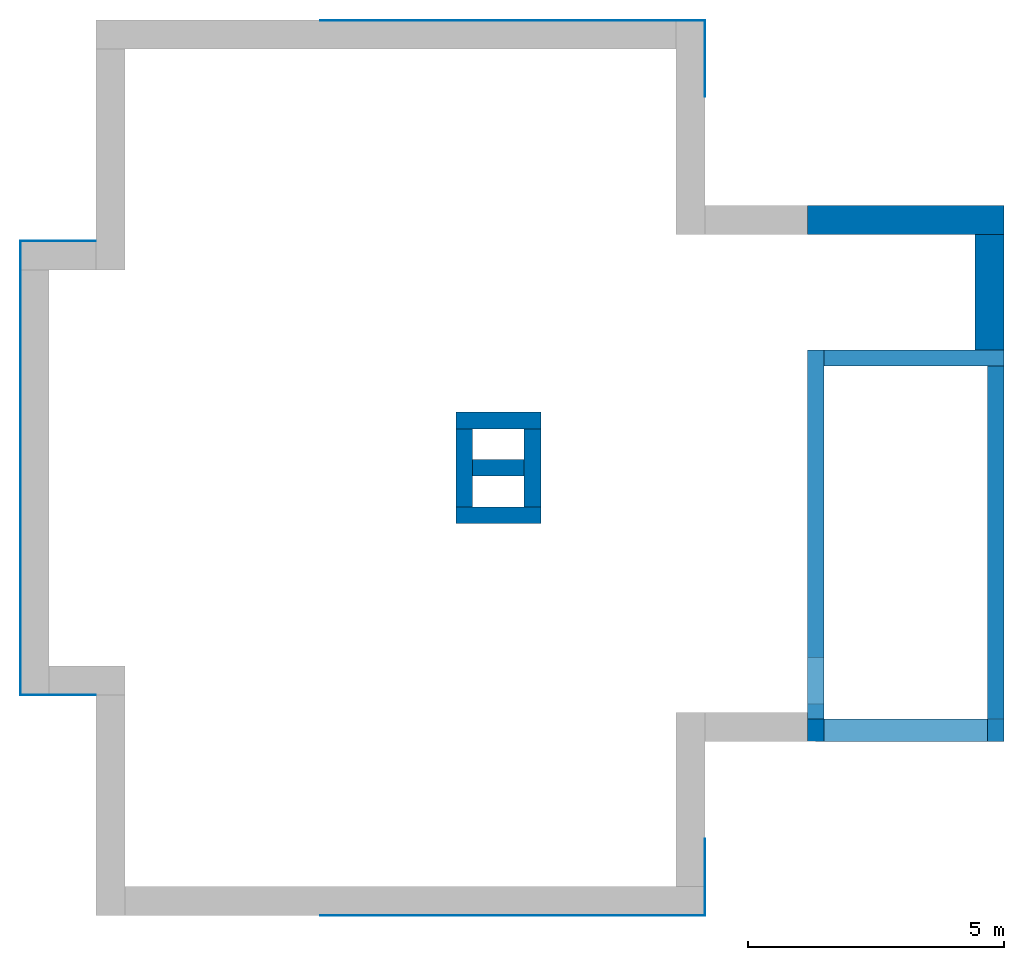
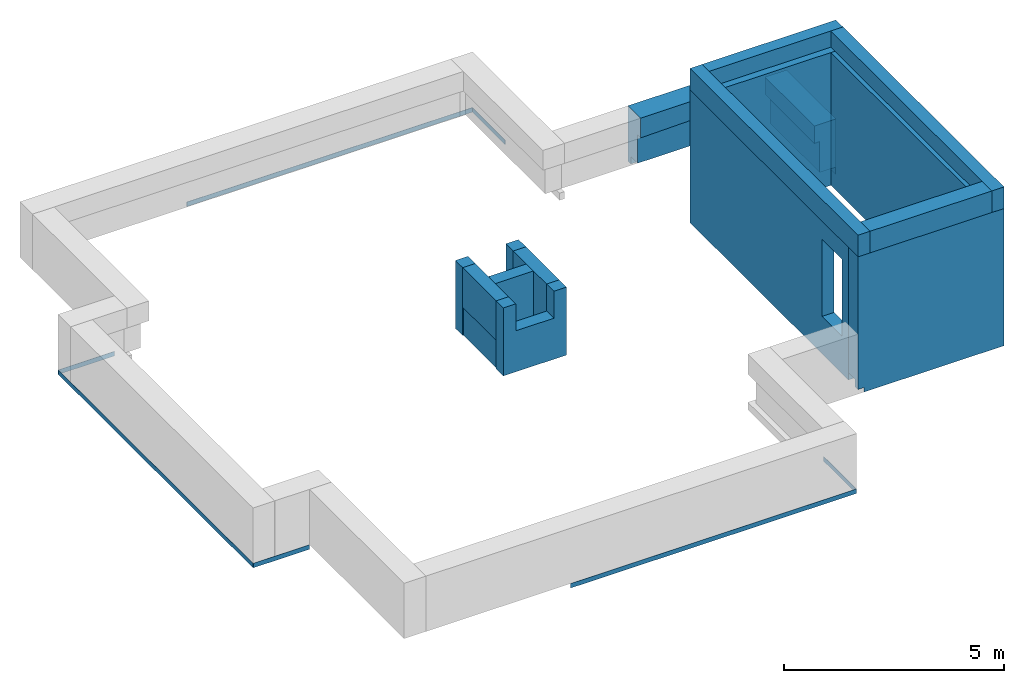
# One storey, part 1 of 2: 22 walls, 6 openings.
"""IFC2X3 building model written with IfcOpenShell, lengths in millimetres."""

from ifc_helpers import new_model, entity, si_unit, converted_unit, derived_unit, direction, frame, frame_2d, origin, origin_2d_with_axis, place, context, subcontext, project, spatial, polyline, rectangle, extrude, clip, bounded_halfspace, faceted_brep, material, material_list, layer, layer_set, layer_usage, type_object, element, save


model = new_model("IFC2X3")

# Units and contexts
model_context = context("Model", 3, precision=0.01, world=origin(), true_north=direction((6.12303176911189e-17, 1.0)))
body_context = subcontext(model_context, "Body", "Model", "MODEL_VIEW")
ifc_project = project(units=[si_unit("LENGTHUNIT", "METRE", prefix="MILLI"), si_unit("AREAUNIT", "SQUARE_METRE"), si_unit("VOLUMEUNIT", "CUBIC_METRE"), converted_unit("PLANEANGLEUNIT", "DEGREE", entity("IfcRatioMeasure", 0.0174532925199433), si_unit("PLANEANGLEUNIT", "RADIAN"), dimensions=[0, 0, 0, 0, 0, 0, 0]), si_unit("MASSUNIT", "GRAM", prefix="KILO"), derived_unit("MASSDENSITYUNIT", [(si_unit("MASSUNIT", "GRAM", prefix="KILO"), 1), (si_unit("LENGTHUNIT", "METRE"), -3)]), si_unit("TIMEUNIT", "SECOND"), si_unit("FREQUENCYUNIT", "HERTZ"), si_unit("THERMODYNAMICTEMPERATUREUNIT", "DEGREE_CELSIUS"), derived_unit("THERMALTRANSMITTANCEUNIT", [(si_unit("MASSUNIT", "GRAM", prefix="KILO"), 1), (si_unit("THERMODYNAMICTEMPERATUREUNIT", "KELVIN"), -1), (si_unit("TIMEUNIT", "SECOND"), -3)]), derived_unit("VOLUMETRICFLOWRATEUNIT", [(si_unit("LENGTHUNIT", "METRE"), 3), (si_unit("TIMEUNIT", "SECOND"), -1)]), si_unit("ELECTRICCURRENTUNIT", "AMPERE"), si_unit("ELECTRICVOLTAGEUNIT", "VOLT"), si_unit("POWERUNIT", "WATT"), si_unit("FORCEUNIT", "NEWTON", prefix="KILO"), si_unit("ILLUMINANCEUNIT", "LUX"), si_unit("LUMINOUSFLUXUNIT", "LUMEN"), si_unit("LUMINOUSINTENSITYUNIT", "CANDELA"), derived_unit("USERDEFINED", [(si_unit("MASSUNIT", "GRAM", prefix="KILO"), -1), (si_unit("LENGTHUNIT", "METRE"), -2), (si_unit("TIMEUNIT", "SECOND"), 3), (si_unit("LUMINOUSFLUXUNIT", "LUMEN"), 1)]), derived_unit("LINEARVELOCITYUNIT", [(si_unit("LENGTHUNIT", "METRE"), 1), (si_unit("TIMEUNIT", "SECOND"), -1)]), si_unit("PRESSUREUNIT", "PASCAL"), derived_unit("USERDEFINED", [(si_unit("LENGTHUNIT", "METRE"), -2), (si_unit("MASSUNIT", "GRAM", prefix="KILO"), 1), (si_unit("TIMEUNIT", "SECOND"), -2)])], contexts=[model_context])

# Site, building, storey
site_placement = place(None, origin())
site = spatial("IfcSite", under=ifc_project, at=site_placement, CompositionType="ELEMENT")
building_placement = place(site_placement, origin())
building = spatial("IfcBuilding", under=site, at=building_placement, CompositionType="ELEMENT")
storey_placement = place(building_placement, frame((0.0, 0.0, 16000.0)))
storey = spatial("IfcBuildingStorey", under=building, at=storey_placement, Name="04 Roof", CompositionType="ELEMENT", Elevation=16000.0)

# Wall
ifc_material_1 = material(Name="03")
ifc_layer_1 = layer(ifc_material_1, 10.0)
ifc_material_2 = material()
ifc_layer_2 = layer(ifc_material_2, 120.0)
ifc_material_3 = material()
ifc_layer_3 = layer(ifc_material_3, 300.0)
ifc_layer_4 = layer(ifc_material_1, 10.0)
ifc_layer_set_1 = layer_set([ifc_layer_1, ifc_layer_2, ifc_layer_3, ifc_layer_4], Name="Basic Wall:00_fal+12 cm")
wall_type_1 = type_object("IfcWallType", Name="Basic Wall:00_fal+12 cm", PredefinedType="STANDARD", material=ifc_layer_set_1)
wall_1_placement = place(storey_placement, frame((30943.4900708518, -73960.8241905963, -465.0)))
element("IfcWall", 1, at=wall_1_placement, inside=storey, type_object=wall_type_1, Name="Basic Wall:00_fal+12 cm", ObjectType="Basic Wall:00_fal+12 cm", context=body_context, shape_type="Brep", body=[
    faceted_brep([(160.0, -220.0, 0.0), (3840.0, -220.0, 0.0), (3840.0, -220.0, 3815.0), (3520.0, -220.0, 3815.0), (320.0, -220.0, 3815.0), (0.0, -220.0, 3815.0), (0.0, -220.0, 1665.0), (0.0, -220.0, 125.0), (160.0, -220.0, 125.0), (0.0, 220.0, 3815.0), (320.0, 220.0, 3815.0), (3520.0, 220.0, 3815.0), (3840.0, 220.0, 3815.0), (3840.0, 220.0, 125.0), (3830.0, 220.0, 125.0), (3830.0, 220.0, 325.0), (3520.0, 220.0, 325.0), (320.0, 220.0, 325.0), (0.0, 220.0, 325.0), (160.0, -210.0, 0.0), (3840.0, -210.0, 0.0), (3840.0, -210.0, 125.0), (160.0, -210.0, 125.0), (0.0, -210.0, 125.0), (0.0, -90.0, 125.0), (3830.0, -90.0, 125.0), (0.0, 210.0, 325.0), (0.0, -90.0, 325.0), (3830.0, -90.0, 325.0)], [[[0, 1, 2, 3, 4, 5, 6, 7, 8]], [[9, 10, 11, 12, 13, 14, 15, 16, 17, 18]], [[1, 0, 19, 20]], [[5, 4, 3, 2, 12, 11, 10, 9]], [[2, 1, 20, 21, 13, 12]], [[0, 8, 22, 19]], [[8, 7, 23, 24, 25, 14, 13, 21, 22]], [[5, 9, 18, 26, 27, 24, 23, 7, 6]], [[15, 28, 27, 26, 18, 17, 16]], [[25, 28, 15, 14]], [[28, 25, 24, 27]], [[22, 21, 20, 19]]]),
])

# Wall, openings
ifc_layer_5 = layer(ifc_material_1, 10.0)
ifc_layer_6 = layer(ifc_material_3, 300.0)
ifc_layer_7 = layer(ifc_material_1, 10.0)
ifc_layer_set_2 = layer_set([ifc_layer_5, ifc_layer_6, ifc_layer_7], Name="Basic Wall:00_fal 300 mm")
ifc_layer_usage_1 = layer_usage(ifc_layer_set_2, "AXIS2", "NEGATIVE", 160.0)
wall_type_2 = type_object("IfcWallType", Name="Basic Wall:00_fal 300 mm", PredefinedType="STANDARD", material=ifc_layer_set_2)
wall_2_placement = place(storey_placement, frame((31103.4900708518, -66525.8241905964, -340.0), z_axis=(0.0, 0.0, 1.0), x_axis=(0.0, -1.0, 0.0)))
wall_2 = element("IfcWallStandardCase", 2, at=wall_2_placement, inside=storey, type_object=wall_type_2, material=ifc_layer_usage_1, Name="Basic Wall:00_fal 300 mm", ObjectType="Basic Wall:00_fal 300 mm", context=body_context, shape_type="SweptSolid", body=[
    extrude(rectangle(XDim=7214.99999999998, YDim=319.999999999997, at=frame_2d((3607.49999999999, 5.11590769747272e-13), x_axis=(-1.0, 0.0))), origin(), (0.0, 0.0, 1.0), 3690.0),
])
opening_1_placement = place(storey_placement, frame((31103.4900708518, -66525.8241905964, -340.0), z_axis=(0.0, 0.0, 1.0), x_axis=(0.0, -1.0, 0.0)))
element("IfcOpeningElement", 3, at=opening_1_placement, cuts=wall_2, Name="Basic Wall:00_fal 300 mm+1", ObjectType="Opening", context=body_context, shape_type="SweptSolid", body=[
    extrude(rectangle(XDim=200.0, YDim=9.9999999999804, at=frame_2d((0.0, -1.08713038571295e-12), x_axis=(0.0, 1.0))), frame((5035.0, 155.0, 100.0), z_axis=(-1.0, 0.0, 0.0), x_axis=(0.0, 1.0, 0.0)), (0.0, 0.0, 1.0), 4724.99999999996),
])
opening_2_placement = place(wall_2_placement, frame((6915.0, -1684.0, 1040.0), z_axis=(0.0, 0.0, 1.0), x_axis=(0.0, 1.0, 0.0)))
element("IfcOpeningElement", 4, at=opening_2_placement, cuts=wall_2, Name="Basic Wall:00_fal 300 mm", ObjectType="Opening", context=body_context, shape_type="SweptSolid", body=[
    extrude(rectangle(XDim=2142.0, YDim=900.000000000003, at=origin_2d_with_axis()), frame((0.0, 450.0, 1071.0), z_axis=(1.0, 0.0, 0.0), x_axis=(0.0, 0.0, 1.0)), (0.0, 0.0, 1.0), 3048.0),
])

# Wall, opening
ifc_layer_usage_2 = layer_usage(ifc_layer_set_2, "AXIS2", "NEGATIVE", 160.0)
wall_3_placement = place(storey_placement, frame((31263.4900708518, -66685.8241905964, -340.0)))
wall_3 = element("IfcWallStandardCase", 5, at=wall_3_placement, inside=storey, type_object=wall_type_2, material=ifc_layer_usage_2, Name="Basic Wall:00_fal 300 mm", ObjectType="Basic Wall:00_fal 300 mm", context=body_context, shape_type="SweptSolid", body=[
    extrude(rectangle(XDim=3519.99999999998, YDim=319.999999999997, at=frame_2d((1759.99999999999, 1.98951966012828e-12), x_axis=(-1.0, 0.0))), origin(), (0.0, 0.0, 1.0), 3690.0),
])
opening_3_placement = place(storey_placement, frame((31263.4900708518, -66685.8241905964, -340.0)))
element("IfcOpeningElement", 6, at=opening_3_placement, cuts=wall_3, Name="Basic Wall:00_fal 300 mm+1", ObjectType="Opening", context=body_context, shape_type="SweptSolid", body=[
    extrude(rectangle(XDim=200.0, YDim=9.99999999999773, at=frame_2d((-1.08713038571295e-12, 0.0), x_axis=(1.0, 0.0))), frame((3210.0, -155.0, 100.0), z_axis=(1.0, 0.0, 0.0), x_axis=(0.0, 0.0, 1.0)), (0.0, 0.0, 1.0), 300.000000000027),
])

ifc_layer_usage_3 = layer_usage(ifc_layer_set_2, "AXIS2", "NEGATIVE", 160.0)
wall_4_placement = place(storey_placement, frame((34623.4900708518, -66845.8241905964, -340.0), z_axis=(0.0, 0.0, 1.0), x_axis=(0.0, -1.0, 0.0)))
wall_4 = element("IfcWallStandardCase", 7, at=wall_4_placement, inside=storey, type_object=wall_type_2, material=ifc_layer_usage_3, Name="Basic Wall:00_fal 300 mm", ObjectType="Basic Wall:00_fal 300 mm", context=body_context, shape_type="SweptSolid", body=[
    extrude(rectangle(XDim=6895.00000000004, YDim=319.999999999997, at=frame_2d((3447.50000000002, 0.0), x_axis=(-1.0, 0.0))), origin(), (0.0, 0.0, 1.0), 3690.0),
])
opening_4_placement = place(storey_placement, frame((34623.4900708518, -66845.8241905964, -340.0), z_axis=(0.0, 0.0, 1.0), x_axis=(0.0, -1.0, 0.0)))
element("IfcOpeningElement", 8, at=opening_4_placement, cuts=wall_4, Name="Basic Wall:00_fal 300 mm+1", ObjectType="Opening", context=body_context, shape_type="SweptSolid", body=[
    extrude(rectangle(XDim=200.0, YDim=4434.99999999997, at=frame_2d((-1.08713038571295e-12, 4.32009983342141e-12), x_axis=(1.0, 0.0))), frame((2217.49999999999, -150.0, 100.0), z_axis=(0.0, 1.0, 0.0), x_axis=(0.0, 0.0, -1.0)), (0.0, 0.0, 1.0), 300.000000000027),
])

# Walls
ifc_layer_usage_4 = layer_usage(ifc_layer_set_2, "AXIS2", "NEGATIVE", 160.0)
wall_5_placement = place(storey_placement, frame((24403.4900708518, -68831.2395851399, -140.0)))
element("IfcWallStandardCase", 9, at=wall_5_placement, inside=storey, type_object=wall_type_2, material=ifc_layer_usage_4, Name="Basic Wall:00_fal 300 mm", ObjectType="Basic Wall:00_fal 300 mm", context=body_context, shape_type="SweptSolid", body=[
    extrude(rectangle(XDim=1000.00000000001, YDim=319.999999999997, at=frame_2d((500.000000000003, -1.56319401867222e-12), x_axis=(-1.0, 0.0))), origin(), (0.0, 0.0, 1.0), 1890.0),
])
ifc_layer_8 = layer(ifc_material_1, 10.0)
ifc_material_4 = material(Name="06_ APP")
ifc_layer_9 = layer(ifc_material_4, 10.0)
ifc_layer_10 = layer(ifc_material_2, 120.0)
ifc_material_5 = material(Name="02_C40/55")
ifc_layer_11 = layer(ifc_material_5, 300.0)
ifc_material_6 = material()
ifc_layer_12 = layer(ifc_material_6, 120.0)
ifc_layer_13 = layer(ifc_material_1, 10.0)
ifc_layer_set_3 = layer_set([ifc_layer_8, ifc_layer_9, ifc_layer_10, ifc_layer_11, ifc_layer_12, ifc_layer_13], Name="Basic Wall:00_beton fal+2x12 cm")
wall_type_3 = type_object("IfcWallType", Name="Basic Wall:00_beton fal+2x12 cm", PredefinedType="STANDARD", material=ifc_layer_set_3)
wall_6_placement = place(storey_placement, frame((34498.4900708518, -64275.8241905964, -340.0), z_axis=(0.0, 0.0, 1.0), x_axis=(0.0, -1.0, 0.0)))
element("IfcWall", 10, at=wall_6_placement, inside=storey, type_object=wall_type_3, Name="Basic Wall:00_beton fal+2x12 cm", ObjectType="Basic Wall:00_beton fal+2x12 cm", context=body_context, shape_type="Brep", body=[
    faceted_brep([(2250.0, -285.0, 1540.0), (0.0, -285.0, 1540.0), (0.0, -285.0, 1057.12609970674), (2250.0, -285.0, 1057.12609970675), (2250.0, 285.0, 0.0), (0.0, 285.0, 0.0), (0.0, 285.0, 1540.0), (2250.0, 285.0, 1540.0), (2250.0, 275.0, 0.0), (0.0, 275.0, 0.0), (0.0, 275.0, 200.0), (0.0, -145.0, 200.0), (0.0, -145.0, 1060.0), (2250.0, -145.0, 1060.0), (2250.0, -145.0, 200.0), (2250.0, 275.0, 200.0)], [[[0, 1, 2, 3]], [[4, 5, 6, 7]], [[5, 4, 8, 9]], [[1, 0, 7, 6]], [[1, 6, 5, 9, 10, 11, 12, 2]], [[13, 12, 11, 14]], [[12, 13, 3, 2]], [[10, 15, 14, 11]], [[15, 10, 9, 8]], [[7, 0, 3, 13, 14, 15, 8, 4]]]),
])
wall_7_placement = place(storey_placement, frame((30943.4900708518, -63990.8241905964, -340.0)))
element("IfcWall", 11, at=wall_7_placement, inside=storey, type_object=wall_type_3, Name="Basic Wall:00_beton fal+2x12 cm", ObjectType="Basic Wall:00_beton fal+2x12 cm", context=body_context, shape_type="Brep", body=[
    faceted_brep([(3840.0, -285.0, 1540.0), (3270.0, -285.0, 1540.0), (0.0, -285.0, 1540.0), (0.0, -285.0, 990.0), (3270.0, -285.0, 1057.12609970674), (3410.0, -285.0, 1060.0), (3410.0, -285.0, 200.0), (3830.0, -285.0, 200.0), (3830.0, -285.0, 0.0), (3840.0, -285.0, 0.0), (3840.0, 285.0, 0.0), (3520.0, 285.0, 0.0), (0.0, 285.0, 0.0), (0.0, 285.0, 1540.0), (3840.0, 285.0, 1540.0), (3830.0, 155.0, 0.0), (0.0, 155.0, 0.0), (0.0, 275.0, 0.0), (0.0, 155.0, 200.0), (0.0, -145.0, 200.0), (0.0, -145.0, 990.0), (3830.0, 155.0, 200.0), (3410.0, -145.0, 200.0), (3410.0, -145.0, 1060.0)], [[[0, 1, 2, 3, 4, 5, 6, 7, 8, 9]], [[10, 11, 12, 13, 14]], [[12, 11, 10, 9, 8, 15, 16, 17]], [[2, 1, 0, 14, 13]], [[13, 12, 17, 16, 18, 19, 20, 3, 2]], [[0, 9, 10, 14]], [[21, 7, 6, 22, 19, 18]], [[21, 15, 8, 7]], [[15, 21, 18, 16]], [[23, 20, 19, 22]], [[23, 22, 6, 5]], [[20, 23, 5, 4, 3]]]),
])
ifc_material_list_1 = material_list([ifc_material_1, ifc_material_4, ifc_material_3, ifc_material_1])
ifc_layer_14 = layer(ifc_material_1, 10.0)
ifc_layer_15 = layer(ifc_material_4, 10.0)
ifc_layer_16 = layer(ifc_material_3, 300.0)
ifc_layer_17 = layer(ifc_material_1, 10.0)
ifc_layer_set_4 = layer_set([ifc_layer_14, ifc_layer_15, ifc_layer_16, ifc_layer_17], Name="Basic Wall:00_fal 300 mm")
wall_type_4 = type_object("IfcWallType", Name="Basic Wall:00_fal 300 mm", PredefinedType="STANDARD", material=ifc_layer_set_4)
wall_8_placement = place(storey_placement, frame((24238.4900708518, -69591.2395851399, -140.0), z_axis=(0.0, 0.0, 1.0), x_axis=(0.0, 1.0, 0.0)))
element("IfcWall", 12, at=wall_8_placement, inside=storey, type_object=wall_type_4, material=ifc_material_list_1, Name="Basic Wall:00_fal 300 mm", ObjectType="Basic Wall:00_fal 300 mm", context=body_context, shape_type="Brep", body=[
    faceted_brep([(0.0, -165.0, 0.0), (600.0, -165.0, 0.0), (920.0, -165.0, 0.0), (1520.0, -165.0, 0.0), (1520.0, -165.0, 1140.0), (1520.0, -165.0, 1890.0), (920.0, -165.0, 1890.0), (600.0, -165.0, 1890.0), (0.0, -165.0, 1890.0), (0.0, -165.0, 1140.0), (0.0, 165.0, 1890.0), (1520.0, 165.0, 1890.0), (1520.0, 165.0, 789.404541657948), (0.0, 165.0, 789.404541657948), (0.0, 145.0, 0.0), (1520.0, 145.0, 0.0), (0.0, 145.0, 790.0), (1520.0, 145.0, 790.0)], [[[0, 1, 2, 3, 4, 5, 6, 7, 8, 9]], [[10, 11, 12, 13]], [[3, 2, 1, 0, 14, 15]], [[8, 7, 6, 5, 11, 10]], [[0, 9, 8, 10, 13, 16, 14]], [[5, 4, 3, 15, 17, 12, 11]], [[16, 17, 15, 14]], [[17, 16, 13, 12]]]),
])

# Wall, opening
ifc_layer_usage_5 = layer_usage(ifc_layer_set_4, "AXIS2", "NEGATIVE", 165.0)
wall_9_placement = place(storey_placement, frame((25733.4900708518, -69756.2395851399, -140.0), z_axis=(0.0, 0.0, 1.0), x_axis=(-1.0, 0.0, 0.0)))
wall_9 = element("IfcWallStandardCase", 13, at=wall_9_placement, inside=storey, type_object=wall_type_4, material=ifc_layer_usage_5, Name="Basic Wall:00_fal 300 mm", ObjectType="Basic Wall:00_fal 300 mm", context=body_context, shape_type="SweptSolid", body=[
    extrude(rectangle(XDim=1660.0, YDim=329.999999999994, at=frame_2d((830.0, 0.0), x_axis=(-1.0, 0.0))), origin(), (0.0, 0.0, 1.0), 1890.0),
])
opening_5_placement = place(wall_9_placement, frame((1330.0, 165.0, 1140.0)))
element("IfcOpeningElement", 14, at=opening_5_placement, cuts=wall_9, Name="Basic Wall:00_fal 300 mm", ObjectType="Opening", context=body_context, shape_type="SweptSolid", body=[
    extrude(rectangle(XDim=750.000000000001, YDim=999.234003431778, at=frame_2d((-1.08002495835535e-12, 2.1600499167107e-12), x_axis=(1.0, 0.0))), frame((-499.617001715887, -330.0, 375.0), z_axis=(0.0, 1.0, 0.0), x_axis=(0.0, 0.0, -1.0)), (0.0, 0.0, 1.0), 329.999999999994),
])

# Wall
ifc_layer_usage_6 = layer_usage(ifc_layer_set_4, "AXIS2", "NEGATIVE", 165.0)
wall_10_placement = place(storey_placement, frame((25568.4900708518, -68071.2395851399, -140.0), z_axis=(0.0, 0.0, 1.0), x_axis=(0.0, -1.0, 0.0)))
element("IfcWallStandardCase", 15, at=wall_10_placement, inside=storey, type_object=wall_type_4, material=ifc_layer_usage_6, Name="Basic Wall:00_fal 300 mm", ObjectType="Basic Wall:00_fal 300 mm", context=body_context, shape_type="Clipping", body=[
    clip(clip(extrude(rectangle(XDim=1519.99999999998, YDim=330.000000000003, at=frame_2d((759.999999999988, -3.69482222595252e-13), x_axis=(-1.0, 0.0))), origin(), (0.0, 0.0, 1.0), 1890.0), bounded_halfspace(frame((1520.0, 145.0, 790.0), z_axis=(0.0, 0.0, 1.0), x_axis=(0.0, -1.0, 0.0)), True, frame((1520.0, 145.0, 790.0), z_axis=(0.0, 0.0, 1.0), x_axis=(0.0, -1.0, 0.0)), polyline([(0.0, 0.0), (-20.0, 0.0), (-20.0, -1520.0), (0.0, -1520.0), (0.0, 0.0)]))), bounded_halfspace(frame((0.0, 145.0, 790.0), z_axis=(0.0, -1.0, 0.0), x_axis=(0.0, 0.0, 1.0)), True, frame((0.0, 145.0, 790.0), z_axis=(0.0, -1.0, 0.0), x_axis=(0.0, 0.0, 1.0)), polyline([(0.0, 0.0), (-790.0, 0.0), (-790.0, -1520.0), (0.0, -1520.0), (0.0, 0.0)]))),
])

# Wall, opening
ifc_layer_usage_7 = layer_usage(ifc_layer_set_4, "AXIS2", "POSITIVE", -165.0)
wall_11_placement = place(storey_placement, frame((25733.4900708518, -67906.23958514, -140.0), z_axis=(0.0, 0.0, 1.0), x_axis=(-1.0, 0.0, 0.0)))
wall_11 = element("IfcWallStandardCase", 16, at=wall_11_placement, inside=storey, type_object=wall_type_4, material=ifc_layer_usage_7, Name="Basic Wall:00_fal 300 mm", ObjectType="Basic Wall:00_fal 300 mm", context=body_context, shape_type="SweptSolid", body=[
    extrude(rectangle(XDim=1660.00000000001, YDim=329.999999999994, at=frame_2d((830.000000000006, 2.24531504500192e-12), x_axis=(-1.0, 0.0))), origin(), (0.0, 0.0, 1.0), 1890.0),
])
opening_6_placement = place(wall_11_placement, frame((1330.0, 165.0, 1140.0)))
element("IfcOpeningElement", 17, at=opening_6_placement, cuts=wall_11, Name="Basic Wall:00_fal 300 mm", ObjectType="Opening", context=body_context, shape_type="SweptSolid", body=[
    extrude(rectangle(XDim=750.000000000001, YDim=999.234003431778, at=frame_2d((-1.08002495835535e-12, -2.1600499167107e-12), x_axis=(1.0, 0.0))), frame((-499.617001715899, -330.0, 375.0), z_axis=(0.0, 1.0, 0.0), x_axis=(0.0, 0.0, -1.0)), (0.0, 0.0, 1.0), 329.999999999994),
])

# Walls
ifc_layer_18 = layer(ifc_material_1, 10.0)
ifc_layer_set_5 = layer_set([ifc_layer_18], Name="Basic Wall:00")
ifc_layer_usage_8 = layer_usage(ifc_layer_set_5, "AXIS2", "NEGATIVE", 5.0)
wall_type_5 = type_object("IfcWallType", Name="Basic Wall:00", PredefinedType="STANDARD", material=ifc_layer_set_5)
wall_12_placement = place(storey_placement, frame((28943.4900708518, -60086.23958514, -465.0), z_axis=(0.0, 0.0, 1.0), x_axis=(-1.0, 0.0, 0.0)))
element("IfcWallStandardCase", 18, at=wall_12_placement, inside=storey, type_object=wall_type_5, material=ifc_layer_usage_8, Name="Basic Wall:00", ObjectType="Basic Wall:00", context=body_context, shape_type="SweptSolid", body=[
    extrude(rectangle(XDim=7519.99999999997, YDim=9.99999999999773, at=frame_2d((3759.99999999999, -1.800781745942e-12), x_axis=(-1.0, 0.0))), origin(), (0.0, 0.0, 1.0), 124.999999999998),
])
ifc_layer_usage_9 = layer_usage(ifc_layer_set_5, "AXIS2", "NEGATIVE", 5.0)
wall_13_placement = place(storey_placement, frame((28938.4900708518, -61581.2395851401, -465.0), z_axis=(0.0, 0.0, 1.0), x_axis=(0.0, 1.0, 0.0)))
element("IfcWallStandardCase", 19, at=wall_13_placement, inside=storey, type_object=wall_type_5, material=ifc_layer_usage_9, Name="Basic Wall:00", ObjectType="Basic Wall:00", context=body_context, shape_type="SweptSolid", body=[
    extrude(rectangle(XDim=1490.00000000007, YDim=9.99999999999773, at=frame_2d((745.000000000034, 9.2326146727828e-13), x_axis=(-1.0, 0.0))), origin(), (0.0, 0.0, 1.0), 124.999999999998),
])
ifc_layer_usage_10 = layer_usage(ifc_layer_set_5, "AXIS2", "POSITIVE", -5.0)
wall_14_placement = place(storey_placement, frame((28943.4900708518, -77576.2395851399, -465.0), z_axis=(0.0, 0.0, 1.0), x_axis=(-1.0, 0.0, 0.0)))
element("IfcWallStandardCase", 20, at=wall_14_placement, inside=storey, type_object=wall_type_5, material=ifc_layer_usage_10, Name="Basic Wall:00", ObjectType="Basic Wall:00", context=body_context, shape_type="SweptSolid", body=[
    extrude(rectangle(XDim=7520.00000000002, YDim=9.99999999999773, at=frame_2d((3760.00000000001, 1.800781745942e-12), x_axis=(-1.0, 0.0))), origin(), (0.0, 0.0, 1.0), 124.999999999998),
])
ifc_layer_usage_11 = layer_usage(ifc_layer_set_5, "AXIS2", "POSITIVE", -5.0)
wall_15_placement = place(storey_placement, frame((28938.4900708518, -76081.2395851399, -465.0), z_axis=(0.0, 0.0, 1.0), x_axis=(0.0, -1.0, 0.0)))
element("IfcWallStandardCase", 21, at=wall_15_placement, inside=storey, type_object=wall_type_5, material=ifc_layer_usage_11, Name="Basic Wall:00", ObjectType="Basic Wall:00", context=body_context, shape_type="SweptSolid", body=[
    extrude(rectangle(XDim=1489.99999999999, YDim=9.99999999999773, at=frame_2d((744.999999999995, -9.2326146727828e-13), x_axis=(-1.0, 0.0))), origin(), (0.0, 0.0, 1.0), 124.999999999998),
])
ifc_layer_usage_12 = layer_usage(ifc_layer_set_5, "AXIS2", "NEGATIVE", 5.0)
wall_16_placement = place(storey_placement, frame((17035.9900708518, -64396.2395851399, -465.0), z_axis=(0.0, 0.0, 1.0), x_axis=(-1.0, 0.0, 0.0)))
element("IfcWallStandardCase", 22, at=wall_16_placement, inside=storey, type_object=wall_type_5, material=ifc_layer_usage_12, Name="Basic Wall:00", ObjectType="Basic Wall:00", context=body_context, shape_type="SweptSolid", body=[
    extrude(rectangle(XDim=1477.49999999999, YDim=9.99999999999773, at=frame_2d((738.749999999994, 2.19912976717751e-12), x_axis=(-1.0, 0.0))), origin(), (0.0, 0.0, 1.0), 124.999999999998),
])
ifc_layer_usage_13 = layer_usage(ifc_layer_set_5, "AXIS2", "NEGATIVE", 5.0)
wall_17_placement = place(storey_placement, frame((15563.4900708518, -64401.2395851399, -465.0), z_axis=(0.0, 0.0, 1.0), x_axis=(0.0, -1.0, 0.0)))
element("IfcWallStandardCase", 23, at=wall_17_placement, inside=storey, type_object=wall_type_5, material=ifc_layer_usage_13, Name="Basic Wall:00", ObjectType="Basic Wall:00", context=body_context, shape_type="SweptSolid", body=[
    extrude(rectangle(XDim=8869.99999999999, YDim=10.0000000000021, at=frame_2d((4434.99999999999, 4.44089209850063e-13), x_axis=(-1.0, 0.0))), origin(), (0.0, 0.0, 1.0), 124.999999999998),
])
ifc_layer_usage_14 = layer_usage(ifc_layer_set_5, "AXIS2", "POSITIVE", -5.0)
wall_18_placement = place(storey_placement, frame((17035.9900708518, -73266.2395851399, -465.0), z_axis=(0.0, 0.0, 1.0), x_axis=(-1.0, 0.0, 0.0)))
element("IfcWallStandardCase", 24, at=wall_18_placement, inside=storey, type_object=wall_type_5, material=ifc_layer_usage_14, Name="Basic Wall:00", ObjectType="Basic Wall:00", context=body_context, shape_type="SweptSolid", body=[
    extrude(rectangle(XDim=1467.49999999997, YDim=9.99999999999773, at=frame_2d((733.749999999983, -1.60271795834888e-12), x_axis=(-1.0, 0.0))), origin(), (0.0, 0.0, 1.0), 124.999999999998),
])
ifc_layer_19 = layer(ifc_material_1, 10.0)
ifc_layer_20 = layer(ifc_material_2, 120.0)
ifc_layer_21 = layer(ifc_material_5, 300.0)
ifc_layer_22 = layer(ifc_material_1, 10.0)
ifc_layer_set_6 = layer_set([ifc_layer_19, ifc_layer_20, ifc_layer_21, ifc_layer_22], Name="Basic Wall:00_beton fal+12 cm 2")
ifc_layer_usage_15 = layer_usage(ifc_layer_set_6, "AXIS2", "POSITIVE", -220.0)
wall_type_6 = type_object("IfcWallType", Name="Basic Wall:00_beton fal+12 cm 2", PredefinedType="STANDARD", material=ifc_layer_set_6)
wall_19_placement = place(storey_placement, frame((31263.4900708518, -73960.8241905963, 3350.0)))
element("IfcWallStandardCase", 25, at=wall_19_placement, inside=storey, type_object=wall_type_6, material=ifc_layer_usage_15, Name="Basic Wall:00_beton fal+12 cm 2", ObjectType="Basic Wall:00_beton fal+12 cm 2", context=body_context, shape_type="Clipping", body=[
    clip(clip(extrude(rectangle(XDim=3199.99999999998, YDim=440.000000000004, at=frame_2d((1599.99999999999, 8.95283847057726e-13), x_axis=(-1.0, 0.0))), origin(), (0.0, 0.0, 1.0), 600.0), bounded_halfspace(frame((3200.0, -90.0, 150.0), z_axis=(0.0, 0.0, 1.0), x_axis=(0.0, 1.0, 0.0)), True, frame((3200.0, -90.0, 150.0), z_axis=(0.0, 0.0, 1.0), x_axis=(0.0, 1.0, 0.0)), polyline([(0.0, 0.0), (310.0, 0.0), (310.0, 3200.0), (0.0, 3200.0), (0.0, 0.0)]))), bounded_halfspace(frame((0.0, -90.0, 150.0), z_axis=(0.0, -1.0, 0.0), x_axis=(0.0, 0.0, 1.0)), True, frame((0.0, -90.0, 150.0), z_axis=(0.0, -1.0, 0.0), x_axis=(0.0, 0.0, 1.0)), polyline([(0.0, 0.0), (-150.0, 0.0), (-150.0, -3200.0), (0.0, -3200.0), (0.0, 0.0)]))),
])
ifc_material_list_2 = material_list([ifc_material_1, ifc_material_5, ifc_material_1])
ifc_layer_23 = layer(ifc_material_1, 10.0)
ifc_layer_24 = layer(ifc_material_5, 300.0)
ifc_layer_25 = layer(ifc_material_1, 10.0)
ifc_layer_set_7 = layer_set([ifc_layer_23, ifc_layer_24, ifc_layer_25], Name="Basic Wall:00_beton fal 300 mm")
wall_type_7 = type_object("IfcWallType", Name="Basic Wall:00_beton fal 300 mm", PredefinedType="STANDARD", material=ifc_layer_set_7)
wall_20_placement = place(storey_placement, frame((34623.4900708518, -66845.8241905964, 3350.0), z_axis=(0.0, 0.0, 1.0), x_axis=(0.0, -1.0, 0.0)))
element("IfcWall", 26, at=wall_20_placement, inside=storey, type_object=wall_type_7, material=ifc_material_list_2, Name="Basic Wall:00_beton fal 300 mm", ObjectType="Basic Wall:00_beton fal 300 mm", context=body_context, shape_type="Brep", body=[
    faceted_brep([(7335.0, -160.0, 600.0), (6895.0, -160.0, 600.0), (0.0, -160.0, 600.0), (0.0, -160.0, 150.0), (6895.0, -160.0, 150.0), (7205.0, -160.0, 150.0), (7205.0, -160.0, 0.0), (7335.0, -160.0, 0.0), (7335.0, 160.0, 0.0), (6895.0, 160.0, 0.0), (0.0, 160.0, 0.0), (0.0, 160.0, 600.0), (7335.0, 160.0, 600.0), (7205.0, 150.0, 0.0), (0.0, 150.0, 0.0), (0.0, 150.0, 150.0), (7205.0, 150.0, 150.0)], [[[0, 1, 2, 3, 4, 5, 6, 7]], [[8, 9, 10, 11, 12]], [[10, 9, 8, 7, 6, 13, 14]], [[2, 1, 0, 12, 11]], [[0, 7, 8, 12]], [[2, 11, 10, 14, 15, 3]], [[15, 16, 5, 4, 3]], [[13, 16, 15, 14]], [[16, 13, 6, 5]]]),
])
wall_21_placement = place(storey_placement, frame((31263.4900708518, -66685.8241905964, 3350.0)))
element("IfcWall", 27, at=wall_21_placement, inside=storey, type_object=wall_type_7, Name="Basic Wall:00_beton fal 300 mm", ObjectType="Basic Wall:00_beton fal 300 mm", context=body_context, shape_type="Brep", body=[
    faceted_brep([(3520.0, -160.0, 600.0), (3200.0, -160.0, 600.0), (0.0, -160.0, 600.0), (0.0, -160.0, 150.0), (3510.0, -160.0, 150.0), (3510.0, -160.0, 0.0), (3520.0, -160.0, 0.0), (3520.0, 160.0, 0.0), (0.0, 160.0, 0.0), (0.0, 160.0, 600.0), (3520.0, 160.0, 600.0), (3510.0, 150.0, 0.0), (0.0, 150.0, 0.0), (0.0, 150.0, 150.0), (3510.0, 150.0, 150.0)], [[[0, 1, 2, 3, 4, 5, 6]], [[7, 8, 9, 10]], [[8, 7, 6, 5, 11, 12]], [[2, 1, 0, 10, 9]], [[10, 0, 6, 7]], [[2, 9, 8, 12, 13, 3]], [[14, 4, 3, 13]], [[14, 11, 5, 4]], [[11, 14, 13, 12]]]),
])
wall_22_placement = place(storey_placement, frame((31103.4900708518, -66525.8241905964, 3350.0), z_axis=(0.0, 0.0, 1.0), x_axis=(0.0, -1.0, 0.0)))
element("IfcWall", 28, at=wall_22_placement, inside=storey, type_object=wall_type_7, Name="Basic Wall:00_beton fal 300 mm", ObjectType="Basic Wall:00_beton fal 300 mm", context=body_context, shape_type="Brep", body=[
    faceted_brep([(0.0, -160.0, 0.0), (7215.0, -160.0, 0.0), (7655.0, -160.0, 0.0), (7655.0, -160.0, 600.0), (0.0, -160.0, 600.0), (0.0, 160.0, 600.0), (320.0, 160.0, 600.0), (7215.0, 160.0, 600.0), (7655.0, 160.0, 600.0), (7655.0, 160.0, 0.0), (7525.0, 160.0, 0.0), (7525.0, 160.0, 150.0), (7215.0, 160.0, 150.0), (10.0, 160.0, 150.0), (10.0, 160.0, 0.0), (0.0, 160.0, 0.0), (10.0, -150.0, 0.0), (7525.0, -150.0, 0.0), (7525.0, -150.0, 150.0), (10.0, -150.0, 150.0)], [[[0, 1, 2, 3, 4]], [[5, 6, 7, 8, 9, 10, 11, 12, 13, 14, 15]], [[2, 1, 0, 15, 14, 16, 17, 10, 9]], [[4, 3, 8, 7, 6, 5]], [[4, 5, 15, 0]], [[8, 3, 2, 9]], [[18, 19, 13, 12, 11]], [[17, 18, 11, 10]], [[19, 18, 17, 16]], [[19, 16, 14, 13]]]),
])

save(model, "model.ifc")
